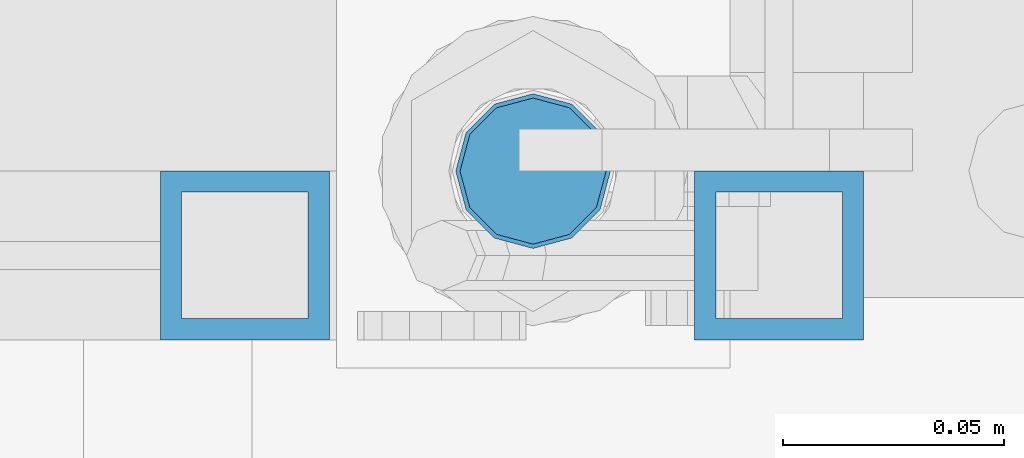
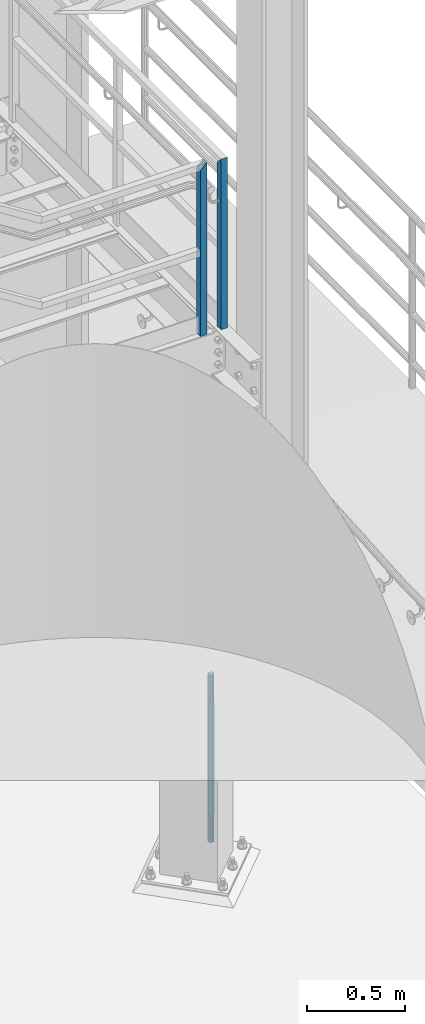
# One storey, part 592 of 1876: 3 columns, 3 elements without a shape of their own.
"""IFC2X3 building model written with IfcOpenShell, lengths in millimetres."""

from ifc_helpers import new_model, si_unit, frame, origin_with_axes, place, context, subcontext, project, spatial, faceted_brep, material, type_object, element, aggregate, save


model = new_model("IFC2X3")

# Units and contexts
model_context = context("Model", 3, precision=1e-05, world=origin_with_axes())
body_context = subcontext(model_context, "Body", "Model", "MODEL_VIEW")
ifc_project = project(units=[si_unit("LENGTHUNIT", "METRE", prefix="MILLI"), si_unit("AREAUNIT", "SQUARE_METRE"), si_unit("VOLUMEUNIT", "CUBIC_METRE"), si_unit("MASSUNIT", "GRAM", prefix="KILO"), si_unit("TIMEUNIT", "SECOND"), si_unit("PLANEANGLEUNIT", "RADIAN"), si_unit("SOLIDANGLEUNIT", "STERADIAN"), si_unit("THERMODYNAMICTEMPERATUREUNIT", "DEGREE_CELSIUS"), si_unit("LUMINOUSINTENSITYUNIT", "LUMEN")], contexts=[model_context])

# Site, building, storey
site_placement = place(None, origin_with_axes())
site = spatial("IfcSite", under=ifc_project, at=site_placement, CompositionType="ELEMENT")
building_placement = place(site_placement, origin_with_axes())
building = spatial("IfcBuilding", under=site, at=building_placement, Name="Undefined", CompositionType="ELEMENT")
storey_placement = place(building_placement, origin_with_axes())
storey = spatial("IfcBuildingStorey", under=building, at=storey_placement, Name="Undefined", CompositionType="ELEMENT", Elevation=0.0)

# Assembly, column
assembly_1_placement = place(storey_placement, origin_with_axes())
assembly_1 = element("IfcElementAssembly", 1, at=assembly_1_placement, inside=storey, Name="RAIL", AssemblyPlace="NOTDEFINED", PredefinedType="RIGID_FRAME")
ifc_material_1 = material()
column_type_1 = type_object("IfcColumnType", Name="HSS1-1/2X1-1/2X3/16", PredefinedType="NOTDEFINED")
column_1_placement = place(assembly_1_placement, frame((7446.9625, -6902.45000113285, 2330.45), z_axis=(0.0, -1.0, 0.0), x_axis=(0.0, 0.0, 1.0)))
column_1 = element("IfcColumn", 2, at=column_1_placement, type_object=column_type_1, material=ifc_material_1, Name="POST", ObjectType="HSS1-1/2X1-1/2X3/16", context=body_context, shape_type="Brep", body=[
    faceted_brep([(0.0, 14.2874994260001, -14.2874994260001), (0.0, -14.2874994260001, -14.2874994260001), (1027.112500574, -14.2874994260001, -14.2874994260001), (1027.112500574, 14.2874994260001, -14.2874994260001), (0.0, -14.2874994260001, 14.2874994260001), (1055.687499426, -14.2874994260001, 14.2874994260001), (0.0, 14.2874994260001, 14.2874994260001), (1055.687499426, 14.2874994260001, 14.2874994260001), (0.0, 19.0499992349996, -19.0499992350001), (0.0, 19.0499992349996, 19.0499992349996), (1060.449999235, 19.0499992349996, 19.0499992349996), (1022.35, 19.0499992349996, -19.0499992349996), (0.0, -19.0499992349996, 19.0499992349996), (1060.449999235, -19.0499992349996, 19.0499992349996), (0.0, -19.0499992349996, -19.0499992350001), (1022.35, -19.0499992349996, -19.0499992349996)], [[[0, 1, 2, 3]], [[1, 4, 5, 2]], [[4, 6, 7, 5]], [[6, 0, 3, 7]], [[8, 9, 10, 11]], [[9, 12, 13, 10]], [[12, 14, 15, 13]], [[14, 8, 11, 15]], [[13, 15, 11, 10], [5, 7, 3, 2]], [[14, 12, 9, 8], [6, 4, 1, 0]]]),
])
aggregate(assembly_1, [column_1])

assembly_2_placement = place(storey_placement, origin_with_axes())
assembly_2 = element("IfcElementAssembly", 3, at=assembly_2_placement, inside=storey, Name="RAIL", AssemblyPlace="NOTDEFINED", PredefinedType="RIGID_FRAME")
column_2_placement = place(assembly_2_placement, frame((7326.31250134362, -6902.45000114554, 2329.68362061127), z_axis=(1.0, 0.0, 0.0), x_axis=(0.0, 0.0, 1.0)))
column_2 = element("IfcColumn", 4, at=column_2_placement, type_object=column_type_1, material=ifc_material_1, Name="POST", ObjectType="HSS1-1/2X1-1/2X3/16", context=body_context, shape_type="Brep", body=[
    faceted_brep([(0.0, 14.2874994260001, -14.2874994260001), (0.0, -14.2874994260001, -14.2874994260001), (1036.63750057105, -14.2874994260001, -14.2874994260001), (1036.63750057105, 14.2874994260001, -14.2874994260001), (0.0, -14.2874994260001, 14.2874994260001), (1065.21249942305, -14.2874994260001, 14.2874994260001), (0.0, 14.2874994260001, 14.2874994260001), (1065.21249942305, 14.2874994260001, 14.2874994260001), (0.0, 19.0499992349996, -19.0499992350001), (0.0, 19.0499992349996, 19.0499992349996), (1069.97499923205, 19.0499992349996, 19.0499992349996), (1031.8749999933, 19.0499992349996, -19.0499992350001), (0.0, -19.0499992349996, 19.0499992349996), (1069.97499923205, -19.0499992349996, 19.0499992349996), (0.0, -19.0499992349996, -19.0499992350001), (1031.8749999933, -19.0499992349996, -19.0499992350001)], [[[0, 1, 2, 3]], [[1, 4, 5, 2]], [[4, 6, 7, 5]], [[6, 0, 3, 7]], [[8, 9, 10, 11]], [[9, 12, 13, 10]], [[12, 14, 15, 13]], [[14, 8, 11, 15]], [[13, 15, 11, 10], [5, 7, 3, 2]], [[14, 12, 9, 8], [6, 4, 1, 0]]]),
])
aggregate(assembly_2, [column_2])

assembly_3_placement = place(storey_placement, origin_with_axes())
assembly_3 = element("IfcElementAssembly", 5, at=assembly_3_placement, inside=storey, Name="TEMPLATE", AssemblyPlace="NOTDEFINED", PredefinedType="RIGID_FRAME")
ifc_material_2 = material(Name="STEEL/F1554-GR.105")
column_type_2 = type_object("IfcColumnType", PredefinedType="NOTDEFINED")
column_3_placement = place(assembly_3_placement, frame((7391.4, -6883.4, 0.0), z_axis=(-1.0, 0.0, 0.0), x_axis=(0.0, 0.0, -1.0)))
column_3 = element("IfcColumn", 6, at=column_3_placement, type_object=column_type_2, material=ifc_material_2, Name="ANCHOR_BOLTS", context=body_context, shape_type="Brep", body=[
    faceted_brep([(-184.15, -14.2894191624437, 8.25), (-184.15, -8.25, 14.2894191624432), (-184.15, 0.0, 16.5), (-184.15, 8.25, 14.2894191624432), (-184.15, 14.2894191624437, 8.25), (-184.15, 16.5, 0.0), (-184.15, 14.2894191624437, -8.25), (-184.15, 8.25, -14.2894191624432), (-184.15, 0.0, -16.5), (-184.15, -8.25, -14.2894191624432), (-184.15, -14.2894191624437, -8.25), (-184.15, -16.5, 0.0), (0.0, 16.5, 0.0), (0.0, 14.2894191624437, -8.25), (0.0, 8.25, -14.2894191624432), (0.0, 0.0, -16.5), (0.0, -8.25, -14.2894191624432), (0.0, -14.2894191624437, -8.25), (0.0, -16.5, 0.0), (0.0, -14.2894191624437, 8.25), (0.0, -8.25, 14.2894191624432), (0.0, 0.0, 16.5), (0.0, 8.25, 14.2894191624432), (0.0, 14.2894191624437, 8.25), (0.0, -15.1229686135858, 8.73125000000073), (0.0, -8.73124999999999, 15.1229686135848), (0.0, 0.0, 17.4625000000015), (0.0, 8.73124999999999, 15.1229686135848), (0.0, 15.1229686135858, 8.73125000000073), (0.0, 17.4625, 0.0), (0.0, 15.1229686135858, -8.73125000000073), (0.0, 8.73124999999999, -15.1229686135848), (0.0, 0.0, -17.4625000000015), (0.0, -8.73124999999999, -15.1229686135848), (0.0, -15.1229686135857, -8.73125000000073), (0.0, -17.4625, 0.0), (692.15, -17.4624999999996, 0.0), (692.15, -15.1229686135857, 8.73124999999982), (692.15, -8.73124999999982, 15.1229686135857), (692.15, 0.0, 17.4624999999996), (692.15, 8.73124999999982, 15.1229686135857), (692.15, 15.1229686135857, 8.73124999999982), (692.15, 17.4624999999996, 0.0), (692.15, 15.1229686135857, -8.73124999999982), (692.15, 8.73124999999982, -15.1229686135857), (692.15, 0.0, -17.4624999999996), (692.15, -8.73124999999982, -15.1229686135857), (692.15, -15.1229686135857, -8.73124999999982), (692.15, -8.25, 14.2894191624437), (692.15, 0.0, 16.5), (692.15, 8.25, 14.2894191624437), (692.15, 14.2894191624437, 8.25), (692.15, 16.5, 0.0), (692.15, 14.2894191624437, -8.25), (692.15, 8.25, -14.2894191624437), (692.15, 0.0, -16.5), (692.15, -8.25, -14.2894191624437), (692.15, -14.2894191624437, -8.25), (692.15, -16.5, 0.0), (692.15, -14.2894191624437, 8.25), (857.25, -8.25, -14.2894191624437), (857.25, 0.0, -16.5), (857.25, 8.25, -14.2894191624437), (857.25, 14.2894191624437, -8.25), (857.25, 16.5, 0.0), (857.25, 14.2894191624437, 8.25), (857.25, 8.25, 14.2894191624437), (857.25, 0.0, 16.5), (857.25, -8.25, 14.2894191624437), (857.25, -14.2894191624437, 8.25), (857.25, -16.5, 0.0), (857.25, -14.2894191624437, -8.25)], [[[0, 1, 2, 3, 4, 5, 6, 7, 8, 9, 10, 11]], [[6, 5, 12, 13]], [[7, 6, 13, 14]], [[8, 7, 14, 15]], [[9, 8, 15, 16]], [[10, 9, 16, 17]], [[11, 10, 17, 18]], [[0, 11, 18, 19]], [[1, 0, 19, 20]], [[2, 1, 20, 21]], [[3, 2, 21, 22]], [[4, 3, 22, 23]], [[5, 4, 23, 12]], [[24, 25, 26, 27, 28, 29, 30, 31, 32, 33, 34, 35], [22, 21, 20, 19, 18, 17, 16, 15, 14, 13, 12, 23]], [[24, 35, 36, 37]], [[25, 24, 37, 38]], [[26, 25, 38, 39]], [[27, 26, 39, 40]], [[28, 27, 40, 41]], [[29, 28, 41, 42]], [[30, 29, 42, 43]], [[31, 30, 43, 44]], [[32, 31, 44, 45]], [[33, 32, 45, 46]], [[34, 33, 46, 47]], [[35, 34, 47, 36]], [[46, 45, 44, 43, 42, 41, 40, 39, 38, 37, 36, 47], [48, 49, 50, 51, 52, 53, 54, 55, 56, 57, 58, 59]], [[60, 61, 62, 63, 64, 65, 66, 67, 68, 69, 70, 71]], [[68, 67, 49, 48]], [[69, 68, 48, 59]], [[70, 69, 59, 58]], [[71, 70, 58, 57]], [[60, 71, 57, 56]], [[61, 60, 56, 55]], [[62, 61, 55, 54]], [[63, 62, 54, 53]], [[64, 63, 53, 52]], [[65, 64, 52, 51]], [[66, 65, 51, 50]], [[67, 66, 50, 49]]]),
])
aggregate(assembly_3, [column_3])

save(model, "model.ifc")
